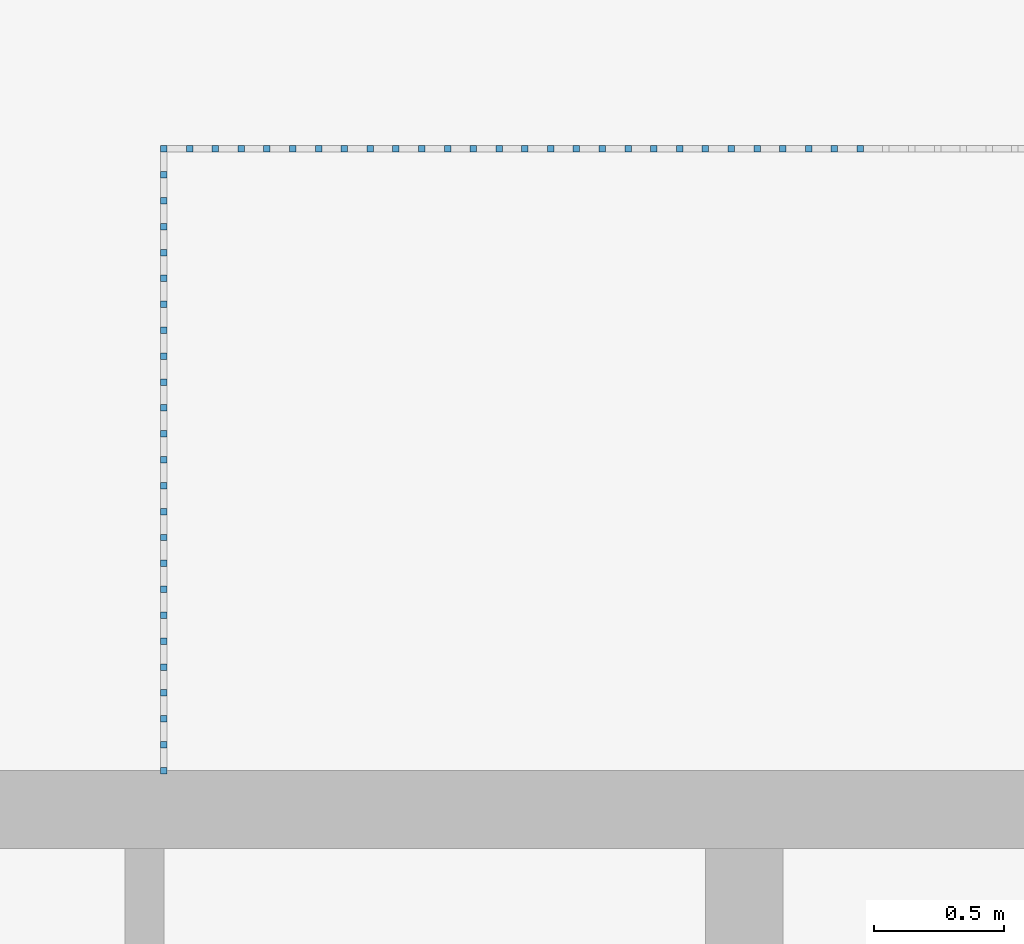
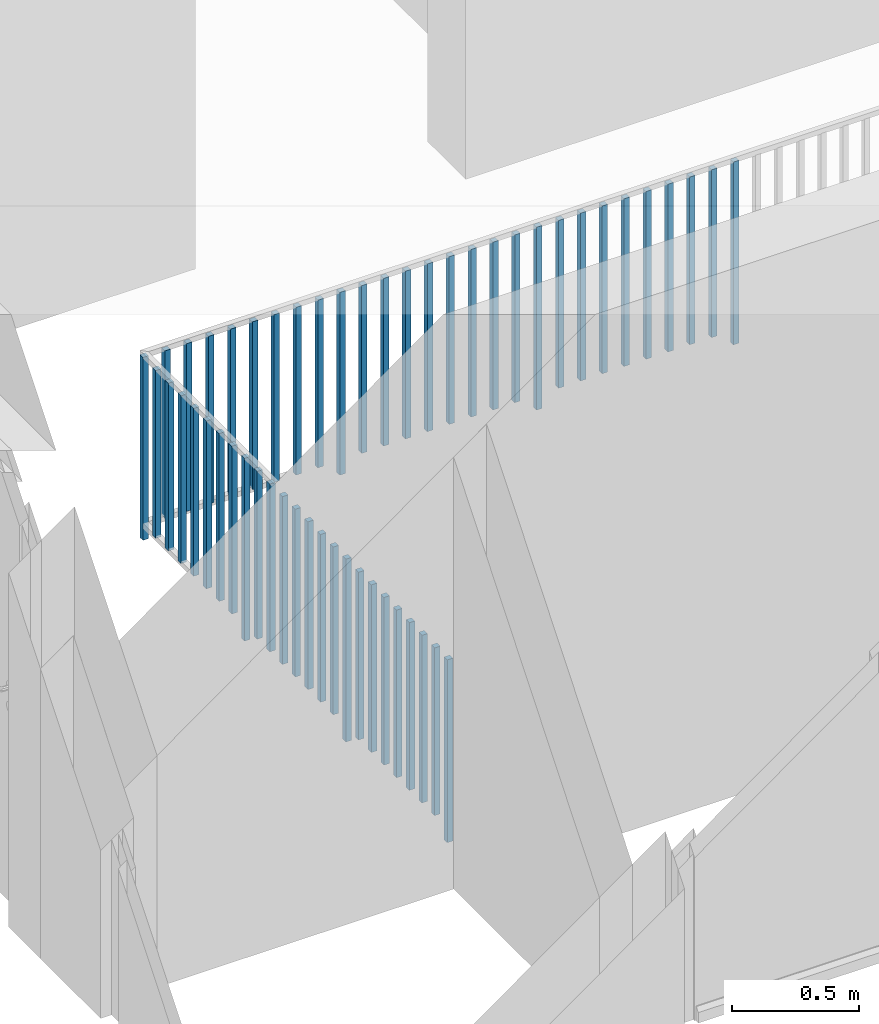
# One storey, part 40 of 54: 52 building element parts, 1 element without a shape of its own.
"""IFC4 building model written with IfcOpenShell, lengths in metres."""

from ifc_helpers import new_model, entity, si_unit, converted_unit, derived_unit, direction, frame, origin_with_axes, place, context, subcontext, project, spatial, polygons, material, type_object, element, aggregate, save


model = new_model("IFC4")

# Units and contexts
model_context = context("Model", 3, precision=1e-05, world=origin_with_axes(), true_north=direction((0.0, 1.0)))
body_context = subcontext(model_context, "Body", "Model", "MODEL_VIEW")
ifc_project = project(units=[si_unit("LENGTHUNIT", "METRE"), si_unit("AREAUNIT", "SQUARE_METRE"), si_unit("VOLUMEUNIT", "CUBIC_METRE"), converted_unit("PLANEANGLEUNIT", "DEGREE", entity("IfcPlaneAngleMeasure", 0.0174532925199), si_unit("PLANEANGLEUNIT", "RADIAN"), dimensions=[0, 0, 0, 0, 0, 0, 0]), converted_unit("TIMEUNIT", "Year", entity("IfcTimeMeasure", 31556926.0), si_unit("TIMEUNIT", "SECOND"), dimensions=[0, 0, 1, 0, 0, 0, 0]), si_unit("MASSUNIT", "GRAM", prefix="KILO"), si_unit("THERMODYNAMICTEMPERATUREUNIT", "DEGREE_CELSIUS"), si_unit("LUMINOUSINTENSITYUNIT", "LUMEN"), si_unit("ENERGYUNIT", "JOULE", prefix="MEGA"), derived_unit("THERMALCONDUCTANCEUNIT", [(si_unit("POWERUNIT", "WATT"), 1), (si_unit("LENGTHUNIT", "METRE"), -1), (si_unit("THERMODYNAMICTEMPERATUREUNIT", "KELVIN"), -1)]), derived_unit("SPECIFICHEATCAPACITYUNIT", [(si_unit("ENERGYUNIT", "JOULE"), 1), (si_unit("MASSUNIT", "GRAM", prefix="KILO"), -1), (si_unit("THERMODYNAMICTEMPERATUREUNIT", "KELVIN"), -1)]), derived_unit("MASSDENSITYUNIT", [(si_unit("MASSUNIT", "GRAM", prefix="KILO"), 1), (si_unit("VOLUMEUNIT", "CUBIC_METRE"), -1)])], contexts=[model_context])

# Site, building, storey, space
site_placement = place(None, origin_with_axes())
site = spatial("IfcSite", under=ifc_project, at=site_placement, CompositionType="ELEMENT")
building_placement = place(site_placement, origin_with_axes())
building = spatial("IfcBuilding", under=site, at=building_placement, CompositionType="ELEMENT")
storey_placement = place(building_placement, frame((0.0, 0.0, 9.18), z_axis=(0.0, 0.0, 1.0), x_axis=(1.0, 0.0, 0.0)))
storey = spatial("IfcBuildingStorey", under=building, at=storey_placement, Name="3. Geschoss", CompositionType="ELEMENT", Elevation=9.18)
space_placement = place(storey_placement, frame((-3.4421993804, -2.52881223104, 0.0), z_axis=(0.0, 0.0, 1.0), x_axis=(1.0, 0.0, 0.0)))
space = spatial("IfcSpace", under=storey, at=space_placement, CompositionType="ELEMENT", PredefinedType="INTERNAL")

# Railing, building element parts
railing_type = type_object("IfcRailingType", PredefinedType="NOTDEFINED")
railing_placement = place(space_placement, frame((0.0, 1.5, 0.0), z_axis=(0.0, 0.0, 1.0), x_axis=(1.0, 0.0, 0.0)))
railing = element("IfcRailing", 1, at=railing_placement, inside=space, type_object=railing_type, PredefinedType="NOTDEFINED")
ifc_material = material()
building_element_part_1_placement = place(railing_placement, origin_with_axes())
building_element_part_1 = element("IfcBuildingElementPart", 2, at=building_element_part_1_placement, material=ifc_material, PredefinedType="NOTDEFINED", context=body_context, shape_type="Tessellation", body=[
    polygons([(0.0125, -1.4875, 0.0), (-0.0125, -1.4875, 0.0), (-0.0125, -1.4875, 0.88), (0.0125, -1.4875, 0.88), (0.0125, -1.5125, 0.0), (-0.0125, -1.5125, 0.0), (-0.0125, -1.5125, 0.88), (0.0125, -1.5125, 0.88)], [[[1, 2, 3, 4]], [[1, 5, 6, 2]], [[2, 6, 7, 3]], [[4, 3, 7, 8]], [[5, 1, 4, 8]], [[6, 5, 8, 7]]], closed=True),
])
building_element_part_2_placement = place(railing_placement, origin_with_axes())
building_element_part_2 = element("IfcBuildingElementPart", 3, at=building_element_part_2_placement, material=ifc_material, PredefinedType="NOTDEFINED", context=body_context, shape_type="Tessellation", body=[
    polygons([(0.0125, 0.9125, 0.0), (-0.0125, 0.9125, 0.0), (-0.0125, 0.9125, 0.88), (0.0125, 0.9125, 0.88), (0.0125, 0.8875, 0.0), (-0.0125, 0.8875, 0.0), (-0.0125, 0.8875, 0.88), (0.0125, 0.8875, 0.88)], [[[1, 2, 3, 4]], [[1, 5, 6, 2]], [[2, 6, 7, 3]], [[4, 3, 7, 8]], [[5, 1, 4, 8]], [[6, 5, 8, 7]]], closed=True),
])
building_element_part_3_placement = place(railing_placement, origin_with_axes())
building_element_part_3 = element("IfcBuildingElementPart", 4, at=building_element_part_3_placement, material=ifc_material, PredefinedType="NOTDEFINED", context=body_context, shape_type="Tessellation", body=[
    polygons([(0.0125, -1.3875, 0.07), (-0.0125, -1.3875, 0.07), (-0.0125, -1.3875, 0.8775), (0.0125, -1.3875, 0.8775), (0.0125, -1.4125, 0.07), (-0.0125, -1.4125, 0.07), (-0.0125, -1.4125, 0.8775), (0.0125, -1.4125, 0.8775)], [[[1, 2, 3, 4]], [[1, 5, 6, 2]], [[2, 6, 7, 3]], [[4, 3, 7, 8]], [[5, 1, 4, 8]], [[6, 5, 8, 7]]], closed=True),
])
building_element_part_4_placement = place(railing_placement, origin_with_axes())
building_element_part_4 = element("IfcBuildingElementPart", 5, at=building_element_part_4_placement, material=ifc_material, PredefinedType="NOTDEFINED", context=body_context, shape_type="Tessellation", body=[
    polygons([(0.0125, -1.2875, 0.07), (-0.0125, -1.2875, 0.07), (-0.0125, -1.2875, 0.8775), (0.0125, -1.2875, 0.8775), (0.0125, -1.3125, 0.07), (-0.0125, -1.3125, 0.07), (-0.0125, -1.3125, 0.8775), (0.0125, -1.3125, 0.8775)], [[[1, 2, 3, 4]], [[1, 5, 6, 2]], [[2, 6, 7, 3]], [[4, 3, 7, 8]], [[5, 1, 4, 8]], [[6, 5, 8, 7]]], closed=True),
])
building_element_part_5_placement = place(railing_placement, origin_with_axes())
building_element_part_5 = element("IfcBuildingElementPart", 6, at=building_element_part_5_placement, material=ifc_material, PredefinedType="NOTDEFINED", context=body_context, shape_type="Tessellation", body=[
    polygons([(0.0125, -1.1875, 0.07), (-0.0125, -1.1875, 0.07), (-0.0125, -1.1875, 0.8775), (0.0125, -1.1875, 0.8775), (0.0125, -1.2125, 0.07), (-0.0125, -1.2125, 0.07), (-0.0125, -1.2125, 0.8775), (0.0125, -1.2125, 0.8775)], [[[1, 2, 3, 4]], [[1, 5, 6, 2]], [[2, 6, 7, 3]], [[4, 3, 7, 8]], [[5, 1, 4, 8]], [[6, 5, 8, 7]]], closed=True),
])
building_element_part_6_placement = place(railing_placement, origin_with_axes())
building_element_part_6 = element("IfcBuildingElementPart", 7, at=building_element_part_6_placement, material=ifc_material, PredefinedType="NOTDEFINED", context=body_context, shape_type="Tessellation", body=[
    polygons([(0.0125, -1.0875, 0.07), (-0.0125, -1.0875, 0.07), (-0.0125, -1.0875, 0.8775), (0.0125, -1.0875, 0.8775), (0.0125, -1.1125, 0.07), (-0.0125, -1.1125, 0.07), (-0.0125, -1.1125, 0.8775), (0.0125, -1.1125, 0.8775)], [[[1, 2, 3, 4]], [[1, 5, 6, 2]], [[2, 6, 7, 3]], [[4, 3, 7, 8]], [[5, 1, 4, 8]], [[6, 5, 8, 7]]], closed=True),
])
building_element_part_7_placement = place(railing_placement, origin_with_axes())
building_element_part_7 = element("IfcBuildingElementPart", 8, at=building_element_part_7_placement, material=ifc_material, PredefinedType="NOTDEFINED", context=body_context, shape_type="Tessellation", body=[
    polygons([(0.0125, -0.9875, 0.07), (-0.0125, -0.9875, 0.07), (-0.0125, -0.9875, 0.8775), (0.0125, -0.9875, 0.8775), (0.0125, -1.0125, 0.07), (-0.0125, -1.0125, 0.07), (-0.0125, -1.0125, 0.8775), (0.0125, -1.0125, 0.8775)], [[[1, 2, 3, 4]], [[1, 5, 6, 2]], [[2, 6, 7, 3]], [[4, 3, 7, 8]], [[5, 1, 4, 8]], [[6, 5, 8, 7]]], closed=True),
])
building_element_part_8_placement = place(railing_placement, origin_with_axes())
building_element_part_8 = element("IfcBuildingElementPart", 9, at=building_element_part_8_placement, material=ifc_material, PredefinedType="NOTDEFINED", context=body_context, shape_type="Tessellation", body=[
    polygons([(0.0125, -0.8875, 0.07), (-0.0125, -0.8875, 0.07), (-0.0125, -0.8875, 0.8775), (0.0125, -0.8875, 0.8775), (0.0125, -0.9125, 0.07), (-0.0125, -0.9125, 0.07), (-0.0125, -0.9125, 0.8775), (0.0125, -0.9125, 0.8775)], [[[1, 2, 3, 4]], [[1, 5, 6, 2]], [[2, 6, 7, 3]], [[4, 3, 7, 8]], [[5, 1, 4, 8]], [[6, 5, 8, 7]]], closed=True),
])
building_element_part_9_placement = place(railing_placement, origin_with_axes())
building_element_part_9 = element("IfcBuildingElementPart", 10, at=building_element_part_9_placement, material=ifc_material, PredefinedType="NOTDEFINED", context=body_context, shape_type="Tessellation", body=[
    polygons([(0.0125, -0.7875, 0.07), (-0.0125, -0.7875, 0.07), (-0.0125, -0.7875, 0.8775), (0.0125, -0.7875, 0.8775), (0.0125, -0.8125, 0.07), (-0.0125, -0.8125, 0.07), (-0.0125, -0.8125, 0.8775), (0.0125, -0.8125, 0.8775)], [[[1, 2, 3, 4]], [[1, 5, 6, 2]], [[2, 6, 7, 3]], [[4, 3, 7, 8]], [[5, 1, 4, 8]], [[6, 5, 8, 7]]], closed=True),
])
building_element_part_10_placement = place(railing_placement, origin_with_axes())
building_element_part_10 = element("IfcBuildingElementPart", 11, at=building_element_part_10_placement, material=ifc_material, PredefinedType="NOTDEFINED", context=body_context, shape_type="Tessellation", body=[
    polygons([(0.0125, -0.6875, 0.0), (-0.0125, -0.6875, 0.0), (-0.0125, -0.6875, 0.88), (0.0125, -0.6875, 0.88), (0.0125, -0.7125, 0.0), (-0.0125, -0.7125, 0.0), (-0.0125, -0.7125, 0.88), (0.0125, -0.7125, 0.88)], [[[1, 2, 3, 4]], [[1, 5, 6, 2]], [[2, 6, 7, 3]], [[4, 3, 7, 8]], [[5, 1, 4, 8]], [[6, 5, 8, 7]]], closed=True),
])
building_element_part_11_placement = place(railing_placement, origin_with_axes())
building_element_part_11 = element("IfcBuildingElementPart", 12, at=building_element_part_11_placement, material=ifc_material, PredefinedType="NOTDEFINED", context=body_context, shape_type="Tessellation", body=[
    polygons([(0.0125, -0.5875, 0.07), (-0.0125, -0.5875, 0.07), (-0.0125, -0.5875, 0.8775), (0.0125, -0.5875, 0.8775), (0.0125, -0.6125, 0.07), (-0.0125, -0.6125, 0.07), (-0.0125, -0.6125, 0.8775), (0.0125, -0.6125, 0.8775)], [[[1, 2, 3, 4]], [[1, 5, 6, 2]], [[2, 6, 7, 3]], [[4, 3, 7, 8]], [[5, 1, 4, 8]], [[6, 5, 8, 7]]], closed=True),
])
building_element_part_12_placement = place(railing_placement, origin_with_axes())
building_element_part_12 = element("IfcBuildingElementPart", 13, at=building_element_part_12_placement, material=ifc_material, PredefinedType="NOTDEFINED", context=body_context, shape_type="Tessellation", body=[
    polygons([(0.0125, -0.4875, 0.07), (-0.0125, -0.4875, 0.07), (-0.0125, -0.4875, 0.8775), (0.0125, -0.4875, 0.8775), (0.0125, -0.5125, 0.07), (-0.0125, -0.5125, 0.07), (-0.0125, -0.5125, 0.8775), (0.0125, -0.5125, 0.8775)], [[[1, 2, 3, 4]], [[1, 5, 6, 2]], [[2, 6, 7, 3]], [[4, 3, 7, 8]], [[5, 1, 4, 8]], [[6, 5, 8, 7]]], closed=True),
])
building_element_part_13_placement = place(railing_placement, origin_with_axes())
building_element_part_13 = element("IfcBuildingElementPart", 14, at=building_element_part_13_placement, material=ifc_material, PredefinedType="NOTDEFINED", context=body_context, shape_type="Tessellation", body=[
    polygons([(0.0125, -0.3875, 0.07), (-0.0125, -0.3875, 0.07), (-0.0125, -0.3875, 0.8775), (0.0125, -0.3875, 0.8775), (0.0125, -0.4125, 0.07), (-0.0125, -0.4125, 0.07), (-0.0125, -0.4125, 0.8775), (0.0125, -0.4125, 0.8775)], [[[1, 2, 3, 4]], [[1, 5, 6, 2]], [[2, 6, 7, 3]], [[4, 3, 7, 8]], [[5, 1, 4, 8]], [[6, 5, 8, 7]]], closed=True),
])
building_element_part_14_placement = place(railing_placement, origin_with_axes())
building_element_part_14 = element("IfcBuildingElementPart", 15, at=building_element_part_14_placement, material=ifc_material, PredefinedType="NOTDEFINED", context=body_context, shape_type="Tessellation", body=[
    polygons([(0.0125, -0.2875, 0.07), (-0.0125, -0.2875, 0.07), (-0.0125, -0.2875, 0.8775), (0.0125, -0.2875, 0.8775), (0.0125, -0.3125, 0.07), (-0.0125, -0.3125, 0.07), (-0.0125, -0.3125, 0.8775), (0.0125, -0.3125, 0.8775)], [[[1, 2, 3, 4]], [[1, 5, 6, 2]], [[2, 6, 7, 3]], [[4, 3, 7, 8]], [[5, 1, 4, 8]], [[6, 5, 8, 7]]], closed=True),
])
building_element_part_15_placement = place(railing_placement, origin_with_axes())
building_element_part_15 = element("IfcBuildingElementPart", 16, at=building_element_part_15_placement, material=ifc_material, PredefinedType="NOTDEFINED", context=body_context, shape_type="Tessellation", body=[
    polygons([(0.0125, -0.1875, 0.07), (-0.0125, -0.1875, 0.07), (-0.0125, -0.1875, 0.8775), (0.0125, -0.1875, 0.8775), (0.0125, -0.2125, 0.07), (-0.0125, -0.2125, 0.07), (-0.0125, -0.2125, 0.8775), (0.0125, -0.2125, 0.8775)], [[[1, 2, 3, 4]], [[1, 5, 6, 2]], [[2, 6, 7, 3]], [[4, 3, 7, 8]], [[5, 1, 4, 8]], [[6, 5, 8, 7]]], closed=True),
])
building_element_part_16_placement = place(railing_placement, origin_with_axes())
building_element_part_16 = element("IfcBuildingElementPart", 17, at=building_element_part_16_placement, material=ifc_material, PredefinedType="NOTDEFINED", context=body_context, shape_type="Tessellation", body=[
    polygons([(0.0125, -0.0875, 0.07), (-0.0125, -0.0875, 0.07), (-0.0125, -0.0875, 0.8775), (0.0125, -0.0875, 0.8775), (0.0125, -0.1125, 0.07), (-0.0125, -0.1125, 0.07), (-0.0125, -0.1125, 0.8775), (0.0125, -0.1125, 0.8775)], [[[1, 2, 3, 4]], [[1, 5, 6, 2]], [[2, 6, 7, 3]], [[4, 3, 7, 8]], [[5, 1, 4, 8]], [[6, 5, 8, 7]]], closed=True),
])
building_element_part_17_placement = place(railing_placement, origin_with_axes())
building_element_part_17 = element("IfcBuildingElementPart", 18, at=building_element_part_17_placement, material=ifc_material, PredefinedType="NOTDEFINED", context=body_context, shape_type="Tessellation", body=[
    polygons([(0.0125, 0.0125, 0.07), (-0.0125, 0.0125, 0.07), (-0.0125, 0.0125, 0.8775), (0.0125, 0.0125, 0.8775), (0.0125, -0.0125, 0.07), (-0.0125, -0.0125, 0.07), (-0.0125, -0.0125, 0.8775), (0.0125, -0.0125, 0.8775)], [[[1, 2, 3, 4]], [[1, 5, 6, 2]], [[2, 6, 7, 3]], [[4, 3, 7, 8]], [[5, 1, 4, 8]], [[6, 5, 8, 7]]], closed=True),
])
building_element_part_18_placement = place(railing_placement, origin_with_axes())
building_element_part_18 = element("IfcBuildingElementPart", 19, at=building_element_part_18_placement, material=ifc_material, PredefinedType="NOTDEFINED", context=body_context, shape_type="Tessellation", body=[
    polygons([(0.0125, 0.1125, 0.0), (-0.0125, 0.1125, 0.0), (-0.0125, 0.1125, 0.88), (0.0125, 0.1125, 0.88), (0.0125, 0.0875, 0.0), (-0.0125, 0.0875, 0.0), (-0.0125, 0.0875, 0.88), (0.0125, 0.0875, 0.88)], [[[1, 2, 3, 4]], [[1, 5, 6, 2]], [[2, 6, 7, 3]], [[4, 3, 7, 8]], [[5, 1, 4, 8]], [[6, 5, 8, 7]]], closed=True),
])
building_element_part_19_placement = place(railing_placement, origin_with_axes())
building_element_part_19 = element("IfcBuildingElementPart", 20, at=building_element_part_19_placement, material=ifc_material, PredefinedType="NOTDEFINED", context=body_context, shape_type="Tessellation", body=[
    polygons([(0.0125, 0.2125, 0.07), (-0.0125, 0.2125, 0.07), (-0.0125, 0.2125, 0.8775), (0.0125, 0.2125, 0.8775), (0.0125, 0.1875, 0.07), (-0.0125, 0.1875, 0.07), (-0.0125, 0.1875, 0.8775), (0.0125, 0.1875, 0.8775)], [[[1, 2, 3, 4]], [[1, 5, 6, 2]], [[2, 6, 7, 3]], [[4, 3, 7, 8]], [[5, 1, 4, 8]], [[6, 5, 8, 7]]], closed=True),
])
building_element_part_20_placement = place(railing_placement, origin_with_axes())
building_element_part_20 = element("IfcBuildingElementPart", 21, at=building_element_part_20_placement, material=ifc_material, PredefinedType="NOTDEFINED", context=body_context, shape_type="Tessellation", body=[
    polygons([(0.0125, 0.3125, 0.07), (-0.0125, 0.3125, 0.07), (-0.0125, 0.3125, 0.8775), (0.0125, 0.3125, 0.8775), (0.0125, 0.2875, 0.07), (-0.0125, 0.2875, 0.07), (-0.0125, 0.2875, 0.8775), (0.0125, 0.2875, 0.8775)], [[[1, 2, 3, 4]], [[1, 5, 6, 2]], [[2, 6, 7, 3]], [[4, 3, 7, 8]], [[5, 1, 4, 8]], [[6, 5, 8, 7]]], closed=True),
])
building_element_part_21_placement = place(railing_placement, origin_with_axes())
building_element_part_21 = element("IfcBuildingElementPart", 22, at=building_element_part_21_placement, material=ifc_material, PredefinedType="NOTDEFINED", context=body_context, shape_type="Tessellation", body=[
    polygons([(0.0125, 0.4125, 0.07), (-0.0125, 0.4125, 0.07), (-0.0125, 0.4125, 0.8775), (0.0125, 0.4125, 0.8775), (0.0125, 0.3875, 0.07), (-0.0125, 0.3875, 0.07), (-0.0125, 0.3875, 0.8775), (0.0125, 0.3875, 0.8775)], [[[1, 2, 3, 4]], [[1, 5, 6, 2]], [[2, 6, 7, 3]], [[4, 3, 7, 8]], [[5, 1, 4, 8]], [[6, 5, 8, 7]]], closed=True),
])
building_element_part_22_placement = place(railing_placement, origin_with_axes())
building_element_part_22 = element("IfcBuildingElementPart", 23, at=building_element_part_22_placement, material=ifc_material, PredefinedType="NOTDEFINED", context=body_context, shape_type="Tessellation", body=[
    polygons([(0.0125, 0.5125, 0.07), (-0.0125, 0.5125, 0.07), (-0.0125, 0.5125, 0.8775), (0.0125, 0.5125, 0.8775), (0.0125, 0.4875, 0.07), (-0.0125, 0.4875, 0.07), (-0.0125, 0.4875, 0.8775), (0.0125, 0.4875, 0.8775)], [[[1, 2, 3, 4]], [[1, 5, 6, 2]], [[2, 6, 7, 3]], [[4, 3, 7, 8]], [[5, 1, 4, 8]], [[6, 5, 8, 7]]], closed=True),
])
building_element_part_23_placement = place(railing_placement, origin_with_axes())
building_element_part_23 = element("IfcBuildingElementPart", 24, at=building_element_part_23_placement, material=ifc_material, PredefinedType="NOTDEFINED", context=body_context, shape_type="Tessellation", body=[
    polygons([(0.0125, 0.6125, 0.07), (-0.0125, 0.6125, 0.07), (-0.0125, 0.6125, 0.8775), (0.0125, 0.6125, 0.8775), (0.0125, 0.5875, 0.07), (-0.0125, 0.5875, 0.07), (-0.0125, 0.5875, 0.8775), (0.0125, 0.5875, 0.8775)], [[[1, 2, 3, 4]], [[1, 5, 6, 2]], [[2, 6, 7, 3]], [[4, 3, 7, 8]], [[5, 1, 4, 8]], [[6, 5, 8, 7]]], closed=True),
])
building_element_part_24_placement = place(railing_placement, origin_with_axes())
building_element_part_24 = element("IfcBuildingElementPart", 25, at=building_element_part_24_placement, material=ifc_material, PredefinedType="NOTDEFINED", context=body_context, shape_type="Tessellation", body=[
    polygons([(0.0125, 0.7125, 0.07), (-0.0125, 0.7125, 0.07), (-0.0125, 0.7125, 0.8775), (0.0125, 0.7125, 0.8775), (0.0125, 0.6875, 0.07), (-0.0125, 0.6875, 0.07), (-0.0125, 0.6875, 0.8775), (0.0125, 0.6875, 0.8775)], [[[1, 2, 3, 4]], [[1, 5, 6, 2]], [[2, 6, 7, 3]], [[4, 3, 7, 8]], [[5, 1, 4, 8]], [[6, 5, 8, 7]]], closed=True),
])
building_element_part_25_placement = place(railing_placement, origin_with_axes())
building_element_part_25 = element("IfcBuildingElementPart", 26, at=building_element_part_25_placement, material=ifc_material, PredefinedType="NOTDEFINED", context=body_context, shape_type="Tessellation", body=[
    polygons([(0.0125, 0.8125, 0.07), (-0.0125, 0.8125, 0.07), (-0.0125, 0.8125, 0.8775), (0.0125, 0.8125, 0.8775), (0.0125, 0.7875, 0.07), (-0.0125, 0.7875, 0.07), (-0.0125, 0.7875, 0.8775), (0.0125, 0.7875, 0.8775)], [[[1, 2, 3, 4]], [[1, 5, 6, 2]], [[2, 6, 7, 3]], [[4, 3, 7, 8]], [[5, 1, 4, 8]], [[6, 5, 8, 7]]], closed=True),
])
building_element_part_26_placement = place(railing_placement, origin_with_axes())
building_element_part_26 = element("IfcBuildingElementPart", 27, at=building_element_part_26_placement, material=ifc_material, PredefinedType="NOTDEFINED", context=body_context, shape_type="Tessellation", body=[
    polygons([(0.112055555556, 0.8875, 0.07), (0.112055555556, 0.9125, 0.07), (0.112055555556, 0.9125, 0.8775), (0.112055555556, 0.8875, 0.8775), (0.0870555555556, 0.8875, 0.07), (0.0870555555556, 0.9125, 0.07), (0.0870555555556, 0.9125, 0.8775), (0.0870555555556, 0.8875, 0.8775)], [[[1, 2, 3, 4]], [[1, 5, 6, 2]], [[2, 6, 7, 3]], [[4, 3, 7, 8]], [[5, 1, 4, 8]], [[6, 5, 8, 7]]], closed=True),
])
building_element_part_27_placement = place(railing_placement, origin_with_axes())
building_element_part_27 = element("IfcBuildingElementPart", 28, at=building_element_part_27_placement, material=ifc_material, PredefinedType="NOTDEFINED", context=body_context, shape_type="Tessellation", body=[
    polygons([(0.211611111111, 0.8875, 0.07), (0.211611111111, 0.9125, 0.07), (0.211611111111, 0.9125, 0.8775), (0.211611111111, 0.8875, 0.8775), (0.186611111111, 0.8875, 0.07), (0.186611111111, 0.9125, 0.07), (0.186611111111, 0.9125, 0.8775), (0.186611111111, 0.8875, 0.8775)], [[[1, 2, 3, 4]], [[1, 5, 6, 2]], [[2, 6, 7, 3]], [[4, 3, 7, 8]], [[5, 1, 4, 8]], [[6, 5, 8, 7]]], closed=True),
])
building_element_part_28_placement = place(railing_placement, origin_with_axes())
building_element_part_28 = element("IfcBuildingElementPart", 29, at=building_element_part_28_placement, material=ifc_material, PredefinedType="NOTDEFINED", context=body_context, shape_type="Tessellation", body=[
    polygons([(0.311166666667, 0.8875, 0.07), (0.311166666667, 0.9125, 0.07), (0.311166666667, 0.9125, 0.8775), (0.311166666667, 0.8875, 0.8775), (0.286166666667, 0.8875, 0.07), (0.286166666667, 0.9125, 0.07), (0.286166666667, 0.9125, 0.8775), (0.286166666667, 0.8875, 0.8775)], [[[1, 2, 3, 4]], [[1, 5, 6, 2]], [[2, 6, 7, 3]], [[4, 3, 7, 8]], [[5, 1, 4, 8]], [[6, 5, 8, 7]]], closed=True),
])
building_element_part_29_placement = place(railing_placement, origin_with_axes())
building_element_part_29 = element("IfcBuildingElementPart", 30, at=building_element_part_29_placement, material=ifc_material, PredefinedType="NOTDEFINED", context=body_context, shape_type="Tessellation", body=[
    polygons([(0.410722222222, 0.8875, 0.07), (0.410722222222, 0.9125, 0.07), (0.410722222222, 0.9125, 0.8775), (0.410722222222, 0.8875, 0.8775), (0.385722222222, 0.8875, 0.07), (0.385722222222, 0.9125, 0.07), (0.385722222222, 0.9125, 0.8775), (0.385722222222, 0.8875, 0.8775)], [[[1, 2, 3, 4]], [[1, 5, 6, 2]], [[2, 6, 7, 3]], [[4, 3, 7, 8]], [[5, 1, 4, 8]], [[6, 5, 8, 7]]], closed=True),
])
building_element_part_30_placement = place(railing_placement, origin_with_axes())
building_element_part_30 = element("IfcBuildingElementPart", 31, at=building_element_part_30_placement, material=ifc_material, PredefinedType="NOTDEFINED", context=body_context, shape_type="Tessellation", body=[
    polygons([(0.510277777778, 0.8875, 0.07), (0.510277777778, 0.9125, 0.07), (0.510277777778, 0.9125, 0.8775), (0.510277777778, 0.8875, 0.8775), (0.485277777778, 0.8875, 0.07), (0.485277777778, 0.9125, 0.07), (0.485277777778, 0.9125, 0.8775), (0.485277777778, 0.8875, 0.8775)], [[[1, 2, 3, 4]], [[1, 5, 6, 2]], [[2, 6, 7, 3]], [[4, 3, 7, 8]], [[5, 1, 4, 8]], [[6, 5, 8, 7]]], closed=True),
])
building_element_part_31_placement = place(railing_placement, origin_with_axes())
building_element_part_31 = element("IfcBuildingElementPart", 32, at=building_element_part_31_placement, material=ifc_material, PredefinedType="NOTDEFINED", context=body_context, shape_type="Tessellation", body=[
    polygons([(0.609833333333, 0.8875, 0.07), (0.609833333333, 0.9125, 0.07), (0.609833333333, 0.9125, 0.8775), (0.609833333333, 0.8875, 0.8775), (0.584833333333, 0.8875, 0.07), (0.584833333333, 0.9125, 0.07), (0.584833333333, 0.9125, 0.8775), (0.584833333333, 0.8875, 0.8775)], [[[1, 2, 3, 4]], [[1, 5, 6, 2]], [[2, 6, 7, 3]], [[4, 3, 7, 8]], [[5, 1, 4, 8]], [[6, 5, 8, 7]]], closed=True),
])
building_element_part_32_placement = place(railing_placement, origin_with_axes())
building_element_part_32 = element("IfcBuildingElementPart", 33, at=building_element_part_32_placement, material=ifc_material, PredefinedType="NOTDEFINED", context=body_context, shape_type="Tessellation", body=[
    polygons([(0.709388888889, 0.8875, 0.07), (0.709388888889, 0.9125, 0.07), (0.709388888889, 0.9125, 0.8775), (0.709388888889, 0.8875, 0.8775), (0.684388888889, 0.8875, 0.07), (0.684388888889, 0.9125, 0.07), (0.684388888889, 0.9125, 0.8775), (0.684388888889, 0.8875, 0.8775)], [[[1, 2, 3, 4]], [[1, 5, 6, 2]], [[2, 6, 7, 3]], [[4, 3, 7, 8]], [[5, 1, 4, 8]], [[6, 5, 8, 7]]], closed=True),
])
building_element_part_33_placement = place(railing_placement, origin_with_axes())
building_element_part_33 = element("IfcBuildingElementPart", 34, at=building_element_part_33_placement, material=ifc_material, PredefinedType="NOTDEFINED", context=body_context, shape_type="Tessellation", body=[
    polygons([(0.808944444444, 0.8875, 0.07), (0.808944444444, 0.9125, 0.07), (0.808944444444, 0.9125, 0.8775), (0.808944444444, 0.8875, 0.8775), (0.783944444444, 0.8875, 0.07), (0.783944444444, 0.9125, 0.07), (0.783944444444, 0.9125, 0.8775), (0.783944444444, 0.8875, 0.8775)], [[[1, 2, 3, 4]], [[1, 5, 6, 2]], [[2, 6, 7, 3]], [[4, 3, 7, 8]], [[5, 1, 4, 8]], [[6, 5, 8, 7]]], closed=True),
])
building_element_part_34_placement = place(railing_placement, origin_with_axes())
building_element_part_34 = element("IfcBuildingElementPart", 35, at=building_element_part_34_placement, material=ifc_material, PredefinedType="NOTDEFINED", context=body_context, shape_type="Tessellation", body=[
    polygons([(0.9085, 0.8875, 0.0), (0.9085, 0.9125, 0.0), (0.9085, 0.9125, 0.88), (0.9085, 0.8875, 0.88), (0.8835, 0.8875, 0.0), (0.8835, 0.9125, 0.0), (0.8835, 0.9125, 0.88), (0.8835, 0.8875, 0.88)], [[[1, 2, 3, 4]], [[1, 5, 6, 2]], [[2, 6, 7, 3]], [[4, 3, 7, 8]], [[5, 1, 4, 8]], [[6, 5, 8, 7]]], closed=True),
])
building_element_part_35_placement = place(railing_placement, origin_with_axes())
building_element_part_35 = element("IfcBuildingElementPart", 36, at=building_element_part_35_placement, material=ifc_material, PredefinedType="NOTDEFINED", context=body_context, shape_type="Tessellation", body=[
    polygons([(1.00805555556, 0.8875, 0.07), (1.00805555556, 0.9125, 0.07), (1.00805555556, 0.9125, 0.8775), (1.00805555556, 0.8875, 0.8775), (0.983055555556, 0.8875, 0.07), (0.983055555556, 0.9125, 0.07), (0.983055555556, 0.9125, 0.8775), (0.983055555556, 0.8875, 0.8775)], [[[1, 2, 3, 4]], [[1, 5, 6, 2]], [[2, 6, 7, 3]], [[4, 3, 7, 8]], [[5, 1, 4, 8]], [[6, 5, 8, 7]]], closed=True),
])
building_element_part_36_placement = place(railing_placement, origin_with_axes())
building_element_part_36 = element("IfcBuildingElementPart", 37, at=building_element_part_36_placement, material=ifc_material, PredefinedType="NOTDEFINED", context=body_context, shape_type="Tessellation", body=[
    polygons([(1.10761111111, 0.8875, 0.07), (1.10761111111, 0.9125, 0.07), (1.10761111111, 0.9125, 0.8775), (1.10761111111, 0.8875, 0.8775), (1.08261111111, 0.8875, 0.07), (1.08261111111, 0.9125, 0.07), (1.08261111111, 0.9125, 0.8775), (1.08261111111, 0.8875, 0.8775)], [[[1, 2, 3, 4]], [[1, 5, 6, 2]], [[2, 6, 7, 3]], [[4, 3, 7, 8]], [[5, 1, 4, 8]], [[6, 5, 8, 7]]], closed=True),
])
building_element_part_37_placement = place(railing_placement, origin_with_axes())
building_element_part_37 = element("IfcBuildingElementPart", 38, at=building_element_part_37_placement, material=ifc_material, PredefinedType="NOTDEFINED", context=body_context, shape_type="Tessellation", body=[
    polygons([(1.20716666667, 0.8875, 0.07), (1.20716666667, 0.9125, 0.07), (1.20716666667, 0.9125, 0.8775), (1.20716666667, 0.8875, 0.8775), (1.18216666667, 0.8875, 0.07), (1.18216666667, 0.9125, 0.07), (1.18216666667, 0.9125, 0.8775), (1.18216666667, 0.8875, 0.8775)], [[[1, 2, 3, 4]], [[1, 5, 6, 2]], [[2, 6, 7, 3]], [[4, 3, 7, 8]], [[5, 1, 4, 8]], [[6, 5, 8, 7]]], closed=True),
])
building_element_part_38_placement = place(railing_placement, origin_with_axes())
building_element_part_38 = element("IfcBuildingElementPart", 39, at=building_element_part_38_placement, material=ifc_material, PredefinedType="NOTDEFINED", context=body_context, shape_type="Tessellation", body=[
    polygons([(1.30672222222, 0.8875, 0.07), (1.30672222222, 0.9125, 0.07), (1.30672222222, 0.9125, 0.8775), (1.30672222222, 0.8875, 0.8775), (1.28172222222, 0.8875, 0.07), (1.28172222222, 0.9125, 0.07), (1.28172222222, 0.9125, 0.8775), (1.28172222222, 0.8875, 0.8775)], [[[1, 2, 3, 4]], [[1, 5, 6, 2]], [[2, 6, 7, 3]], [[4, 3, 7, 8]], [[5, 1, 4, 8]], [[6, 5, 8, 7]]], closed=True),
])
building_element_part_39_placement = place(railing_placement, origin_with_axes())
building_element_part_39 = element("IfcBuildingElementPart", 40, at=building_element_part_39_placement, material=ifc_material, PredefinedType="NOTDEFINED", context=body_context, shape_type="Tessellation", body=[
    polygons([(1.40627777778, 0.8875, 0.07), (1.40627777778, 0.9125, 0.07), (1.40627777778, 0.9125, 0.8775), (1.40627777778, 0.8875, 0.8775), (1.38127777778, 0.8875, 0.07), (1.38127777778, 0.9125, 0.07), (1.38127777778, 0.9125, 0.8775), (1.38127777778, 0.8875, 0.8775)], [[[1, 2, 3, 4]], [[1, 5, 6, 2]], [[2, 6, 7, 3]], [[4, 3, 7, 8]], [[5, 1, 4, 8]], [[6, 5, 8, 7]]], closed=True),
])
building_element_part_40_placement = place(railing_placement, origin_with_axes())
building_element_part_40 = element("IfcBuildingElementPart", 41, at=building_element_part_40_placement, material=ifc_material, PredefinedType="NOTDEFINED", context=body_context, shape_type="Tessellation", body=[
    polygons([(1.50583333333, 0.8875, 0.07), (1.50583333333, 0.9125, 0.07), (1.50583333333, 0.9125, 0.8775), (1.50583333333, 0.8875, 0.8775), (1.48083333333, 0.8875, 0.07), (1.48083333333, 0.9125, 0.07), (1.48083333333, 0.9125, 0.8775), (1.48083333333, 0.8875, 0.8775)], [[[1, 2, 3, 4]], [[1, 5, 6, 2]], [[2, 6, 7, 3]], [[4, 3, 7, 8]], [[5, 1, 4, 8]], [[6, 5, 8, 7]]], closed=True),
])
building_element_part_41_placement = place(railing_placement, origin_with_axes())
building_element_part_41 = element("IfcBuildingElementPart", 42, at=building_element_part_41_placement, material=ifc_material, PredefinedType="NOTDEFINED", context=body_context, shape_type="Tessellation", body=[
    polygons([(1.60538888889, 0.8875, 0.07), (1.60538888889, 0.9125, 0.07), (1.60538888889, 0.9125, 0.8775), (1.60538888889, 0.8875, 0.8775), (1.58038888889, 0.8875, 0.07), (1.58038888889, 0.9125, 0.07), (1.58038888889, 0.9125, 0.8775), (1.58038888889, 0.8875, 0.8775)], [[[1, 2, 3, 4]], [[1, 5, 6, 2]], [[2, 6, 7, 3]], [[4, 3, 7, 8]], [[5, 1, 4, 8]], [[6, 5, 8, 7]]], closed=True),
])
building_element_part_42_placement = place(railing_placement, origin_with_axes())
building_element_part_42 = element("IfcBuildingElementPart", 43, at=building_element_part_42_placement, material=ifc_material, PredefinedType="NOTDEFINED", context=body_context, shape_type="Tessellation", body=[
    polygons([(1.70494444444, 0.8875, 0.07), (1.70494444444, 0.9125, 0.07), (1.70494444444, 0.9125, 0.8775), (1.70494444444, 0.8875, 0.8775), (1.67994444444, 0.8875, 0.07), (1.67994444444, 0.9125, 0.07), (1.67994444444, 0.9125, 0.8775), (1.67994444444, 0.8875, 0.8775)], [[[1, 2, 3, 4]], [[1, 5, 6, 2]], [[2, 6, 7, 3]], [[4, 3, 7, 8]], [[5, 1, 4, 8]], [[6, 5, 8, 7]]], closed=True),
])
building_element_part_43_placement = place(railing_placement, origin_with_axes())
building_element_part_43 = element("IfcBuildingElementPart", 44, at=building_element_part_43_placement, material=ifc_material, PredefinedType="NOTDEFINED", context=body_context, shape_type="Tessellation", body=[
    polygons([(1.8045, 0.8875, 0.0), (1.8045, 0.9125, 0.0), (1.8045, 0.9125, 0.88), (1.8045, 0.8875, 0.88), (1.7795, 0.8875, 0.0), (1.7795, 0.9125, 0.0), (1.7795, 0.9125, 0.88), (1.7795, 0.8875, 0.88)], [[[1, 2, 3, 4]], [[1, 5, 6, 2]], [[2, 6, 7, 3]], [[4, 3, 7, 8]], [[5, 1, 4, 8]], [[6, 5, 8, 7]]], closed=True),
])
building_element_part_44_placement = place(railing_placement, origin_with_axes())
building_element_part_44 = element("IfcBuildingElementPart", 45, at=building_element_part_44_placement, material=ifc_material, PredefinedType="NOTDEFINED", context=body_context, shape_type="Tessellation", body=[
    polygons([(1.90405555556, 0.8875, 0.07), (1.90405555556, 0.9125, 0.07), (1.90405555556, 0.9125, 0.8775), (1.90405555556, 0.8875, 0.8775), (1.87905555556, 0.8875, 0.07), (1.87905555556, 0.9125, 0.07), (1.87905555556, 0.9125, 0.8775), (1.87905555556, 0.8875, 0.8775)], [[[1, 2, 3, 4]], [[1, 5, 6, 2]], [[2, 6, 7, 3]], [[4, 3, 7, 8]], [[5, 1, 4, 8]], [[6, 5, 8, 7]]], closed=True),
])
building_element_part_45_placement = place(railing_placement, origin_with_axes())
building_element_part_45 = element("IfcBuildingElementPart", 46, at=building_element_part_45_placement, material=ifc_material, PredefinedType="NOTDEFINED", context=body_context, shape_type="Tessellation", body=[
    polygons([(2.00361111111, 0.8875, 0.07), (2.00361111111, 0.9125, 0.07), (2.00361111111, 0.9125, 0.8775), (2.00361111111, 0.8875, 0.8775), (1.97861111111, 0.8875, 0.07), (1.97861111111, 0.9125, 0.07), (1.97861111111, 0.9125, 0.8775), (1.97861111111, 0.8875, 0.8775)], [[[1, 2, 3, 4]], [[1, 5, 6, 2]], [[2, 6, 7, 3]], [[4, 3, 7, 8]], [[5, 1, 4, 8]], [[6, 5, 8, 7]]], closed=True),
])
building_element_part_46_placement = place(railing_placement, origin_with_axes())
building_element_part_46 = element("IfcBuildingElementPart", 47, at=building_element_part_46_placement, material=ifc_material, PredefinedType="NOTDEFINED", context=body_context, shape_type="Tessellation", body=[
    polygons([(2.10316666667, 0.8875, 0.07), (2.10316666667, 0.9125, 0.07), (2.10316666667, 0.9125, 0.8775), (2.10316666667, 0.8875, 0.8775), (2.07816666667, 0.8875, 0.07), (2.07816666667, 0.9125, 0.07), (2.07816666667, 0.9125, 0.8775), (2.07816666667, 0.8875, 0.8775)], [[[1, 2, 3, 4]], [[1, 5, 6, 2]], [[2, 6, 7, 3]], [[4, 3, 7, 8]], [[5, 1, 4, 8]], [[6, 5, 8, 7]]], closed=True),
])
building_element_part_47_placement = place(railing_placement, origin_with_axes())
building_element_part_47 = element("IfcBuildingElementPart", 48, at=building_element_part_47_placement, material=ifc_material, PredefinedType="NOTDEFINED", context=body_context, shape_type="Tessellation", body=[
    polygons([(2.20272222222, 0.8875, 0.07), (2.20272222222, 0.9125, 0.07), (2.20272222222, 0.9125, 0.8775), (2.20272222222, 0.8875, 0.8775), (2.17772222222, 0.8875, 0.07), (2.17772222222, 0.9125, 0.07), (2.17772222222, 0.9125, 0.8775), (2.17772222222, 0.8875, 0.8775)], [[[1, 2, 3, 4]], [[1, 5, 6, 2]], [[2, 6, 7, 3]], [[4, 3, 7, 8]], [[5, 1, 4, 8]], [[6, 5, 8, 7]]], closed=True),
])
building_element_part_48_placement = place(railing_placement, origin_with_axes())
building_element_part_48 = element("IfcBuildingElementPart", 49, at=building_element_part_48_placement, material=ifc_material, PredefinedType="NOTDEFINED", context=body_context, shape_type="Tessellation", body=[
    polygons([(2.30227777778, 0.8875, 0.07), (2.30227777778, 0.9125, 0.07), (2.30227777778, 0.9125, 0.8775), (2.30227777778, 0.8875, 0.8775), (2.27727777778, 0.8875, 0.07), (2.27727777778, 0.9125, 0.07), (2.27727777778, 0.9125, 0.8775), (2.27727777778, 0.8875, 0.8775)], [[[1, 2, 3, 4]], [[1, 5, 6, 2]], [[2, 6, 7, 3]], [[4, 3, 7, 8]], [[5, 1, 4, 8]], [[6, 5, 8, 7]]], closed=True),
])
building_element_part_49_placement = place(railing_placement, origin_with_axes())
building_element_part_49 = element("IfcBuildingElementPart", 50, at=building_element_part_49_placement, material=ifc_material, PredefinedType="NOTDEFINED", context=body_context, shape_type="Tessellation", body=[
    polygons([(2.40183333333, 0.8875, 0.07), (2.40183333333, 0.9125, 0.07), (2.40183333333, 0.9125, 0.8775), (2.40183333333, 0.8875, 0.8775), (2.37683333333, 0.8875, 0.07), (2.37683333333, 0.9125, 0.07), (2.37683333333, 0.9125, 0.8775), (2.37683333333, 0.8875, 0.8775)], [[[1, 2, 3, 4]], [[1, 5, 6, 2]], [[2, 6, 7, 3]], [[4, 3, 7, 8]], [[5, 1, 4, 8]], [[6, 5, 8, 7]]], closed=True),
])
building_element_part_50_placement = place(railing_placement, origin_with_axes())
building_element_part_50 = element("IfcBuildingElementPart", 51, at=building_element_part_50_placement, material=ifc_material, PredefinedType="NOTDEFINED", context=body_context, shape_type="Tessellation", body=[
    polygons([(2.50138888889, 0.8875, 0.07), (2.50138888889, 0.9125, 0.07), (2.50138888889, 0.9125, 0.8775), (2.50138888889, 0.8875, 0.8775), (2.47638888889, 0.8875, 0.07), (2.47638888889, 0.9125, 0.07), (2.47638888889, 0.9125, 0.8775), (2.47638888889, 0.8875, 0.8775)], [[[1, 2, 3, 4]], [[1, 5, 6, 2]], [[2, 6, 7, 3]], [[4, 3, 7, 8]], [[5, 1, 4, 8]], [[6, 5, 8, 7]]], closed=True),
])
building_element_part_51_placement = place(railing_placement, origin_with_axes())
building_element_part_51 = element("IfcBuildingElementPart", 52, at=building_element_part_51_placement, material=ifc_material, PredefinedType="NOTDEFINED", context=body_context, shape_type="Tessellation", body=[
    polygons([(2.60094444444, 0.8875, 0.07), (2.60094444444, 0.9125, 0.07), (2.60094444444, 0.9125, 0.8775), (2.60094444444, 0.8875, 0.8775), (2.57594444444, 0.8875, 0.07), (2.57594444444, 0.9125, 0.07), (2.57594444444, 0.9125, 0.8775), (2.57594444444, 0.8875, 0.8775)], [[[1, 2, 3, 4]], [[1, 5, 6, 2]], [[2, 6, 7, 3]], [[4, 3, 7, 8]], [[5, 1, 4, 8]], [[6, 5, 8, 7]]], closed=True),
])
building_element_part_52_placement = place(railing_placement, origin_with_axes())
building_element_part_52 = element("IfcBuildingElementPart", 53, at=building_element_part_52_placement, material=ifc_material, PredefinedType="NOTDEFINED", context=body_context, shape_type="Tessellation", body=[
    polygons([(2.7005, 0.8875, 0.0), (2.7005, 0.9125, 0.0), (2.7005, 0.9125, 0.88), (2.7005, 0.8875, 0.88), (2.6755, 0.8875, 0.0), (2.6755, 0.9125, 0.0), (2.6755, 0.9125, 0.88), (2.6755, 0.8875, 0.88)], [[[1, 2, 3, 4]], [[1, 5, 6, 2]], [[2, 6, 7, 3]], [[4, 3, 7, 8]], [[5, 1, 4, 8]], [[6, 5, 8, 7]]], closed=True),
])
aggregate(railing, [building_element_part_1, building_element_part_2, building_element_part_3, building_element_part_4, building_element_part_5, building_element_part_6, building_element_part_7, building_element_part_8, building_element_part_9, building_element_part_10, building_element_part_11, building_element_part_12, building_element_part_13, building_element_part_14, building_element_part_15, building_element_part_16, building_element_part_17, building_element_part_18, building_element_part_19, building_element_part_20, building_element_part_21, building_element_part_22, building_element_part_23, building_element_part_24, building_element_part_25, building_element_part_26, building_element_part_27, building_element_part_28, building_element_part_29, building_element_part_30, building_element_part_31, building_element_part_32, building_element_part_33, building_element_part_34, building_element_part_35, building_element_part_36, building_element_part_37, building_element_part_38, building_element_part_39, building_element_part_40, building_element_part_41, building_element_part_42, building_element_part_43, building_element_part_44, building_element_part_45, building_element_part_46, building_element_part_47, building_element_part_48, building_element_part_49, building_element_part_50, building_element_part_51, building_element_part_52])

save(model, "model.ifc")
